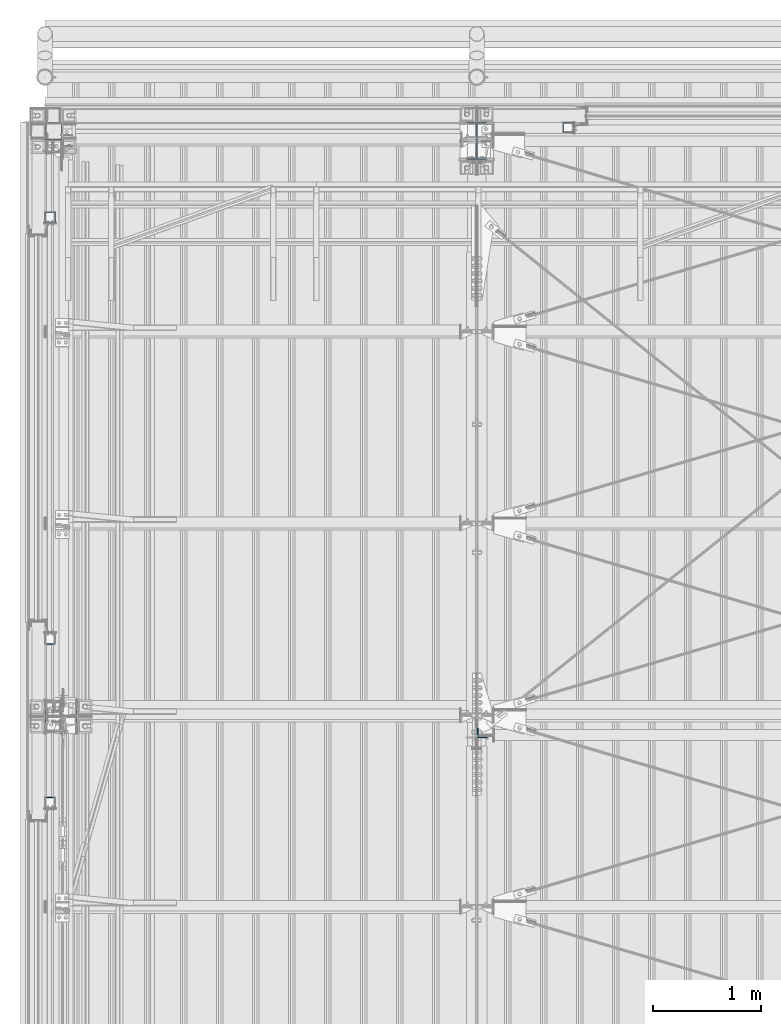
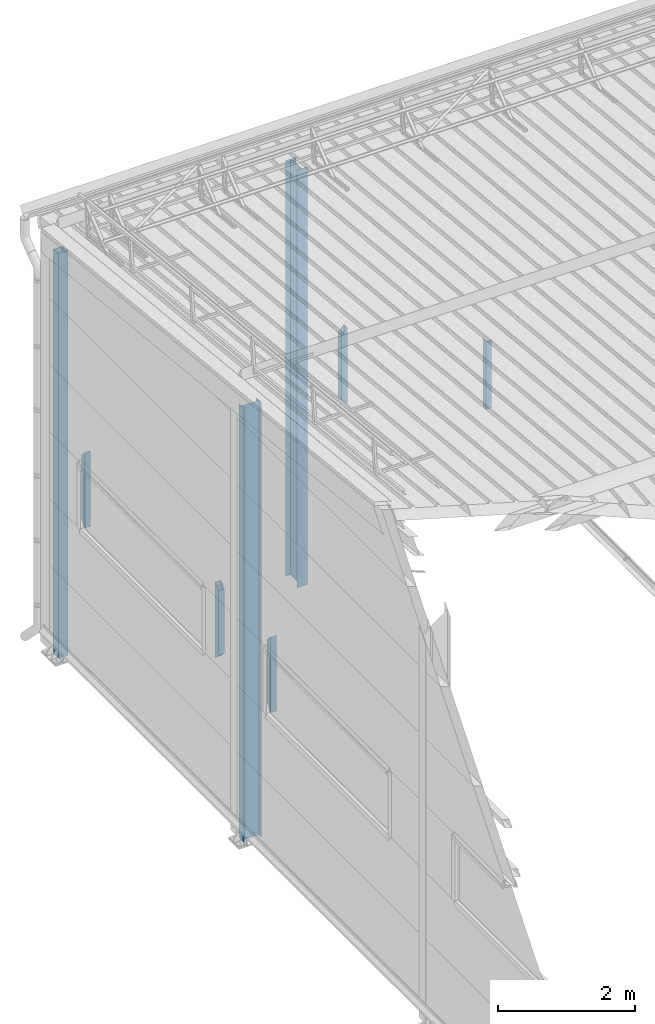
# One storey, part 230 of 709: 8 columns, 8 elements without a shape of their own.
"""IFC4 building model written with IfcOpenShell, lengths in millimetres."""

import ifcopenshell
import ifcopenshell.guid

model = None  # the IFC model being written
_history = None  # IfcOwnerHistory: only IFC2X3 demands one
_inside = {}  # id of a spatial element -> (the spatial element, [elements in it])
_under = {}  # id of a project, library or spatial element -> (it, [spatial elements below it])
_declared = {}  # id of a project -> (the project, [libraries it declares])
_typed = {}  # id of a type object -> (the type object, [elements of that type])
_made_of = {}  # id of a material, layer set ... -> (it, [elements and type objects made of it])


def new_model(schema):
    """Start an empty IFC model of exactly this schema.

    Asked for "IFC4X3", IfcOpenShell would pick the latest addendum, in which some entities
    have other attributes; the version numbers below select the first issue.
    IFC2X3 requires an IfcOwnerHistory on every rooted entity: one is made here for all.
    """
    global model, _history
    if schema == "IFC4X3":
        model = ifcopenshell.file(schema_version=(4, 3, 0, 0))
    else:
        model = ifcopenshell.file(schema=schema)
    _inside.clear()
    _under.clear()
    _declared.clear()
    _typed.clear()
    _made_of.clear()
    _history = None
    if model.schema == "IFC2X3":
        org = make("IfcOrganization", Name="unknown")
        user = make(
            "IfcPersonAndOrganization",
            ThePerson=make("IfcPerson", FamilyName="unknown"),
            TheOrganization=org,
        )
        app = make(
            "IfcApplication",
            ApplicationDeveloper=org,
            Version="unknown",
            ApplicationFullName="unknown",
            ApplicationIdentifier="unknown",
        )
        _history = make(
            "IfcOwnerHistory",
            OwningUser=user,
            OwningApplication=app,
            ChangeAction="ADDED",
            CreationDate=0,
        )
    return model


def make(cls, **values):
    """One entity of the class cls with the attributes given. An attribute that is None is left unset."""
    return model.create_entity(
        cls, **{name: value for name, value in values.items() if value is not None}
    )


def rooted(cls, **values):
    """An entity with a GlobalId (a new one), such as an element, a storey or a relation."""
    return make(cls, GlobalId=ifcopenshell.guid.new(), OwnerHistory=_history, **values)


def si_unit(unit_type, name, prefix=None):
    """IfcSIUnit, for example si_unit("LENGTHUNIT", "METRE", prefix="MILLI")."""
    return make("IfcSIUnit", UnitType=unit_type, Prefix=prefix, Name=name)


def assignment(units):
    """IfcUnitAssignment: the units of a project."""
    return None if units is None else make("IfcUnitAssignment", Units=units)


def point(xyz):
    """IfcCartesianPoint."""
    return None if xyz is None else make("IfcCartesianPoint", Coordinates=xyz)


def direction(xyz):
    """IfcDirection."""
    return None if xyz is None else make("IfcDirection", DirectionRatios=xyz)


def frame(location, z_axis=None, x_axis=None):
    """IfcAxis2Placement3D, a coordinate frame: its origin and axes. An axis left out is left unset."""
    return make(
        "IfcAxis2Placement3D",
        Location=point(location),
        Axis=direction(z_axis),
        RefDirection=direction(x_axis),
    )


def origin_with_axes():
    """The frame at (0, 0, 0) with the z axis (0, 0, 1) and the x axis (1, 0, 0) written out."""
    return frame((0.0, 0.0, 0.0), z_axis=(0.0, 0.0, 1.0), x_axis=(1.0, 0.0, 0.0))


def place(relative_to, where):
    """IfcLocalPlacement: puts the frame where relative to a parent placement (None: the world)."""
    return make(
        "IfcLocalPlacement", PlacementRelTo=relative_to, RelativePlacement=where
    )


def context(
    kind, dimensions, precision=None, world=None, true_north=None, identifier=None
):
    """IfcGeometricRepresentationContext, for example the 3D "Model" context."""
    return make(
        "IfcGeometricRepresentationContext",
        ContextIdentifier=identifier,
        ContextType=kind,
        CoordinateSpaceDimension=dimensions,
        Precision=precision,
        WorldCoordinateSystem=world,
        TrueNorth=true_north,
    )


def subcontext(parent, identifier, kind, view, scale=None):
    """IfcGeometricRepresentationSubContext, for example "Body" below "Model"."""
    return make(
        "IfcGeometricRepresentationSubContext",
        ContextIdentifier=identifier,
        ContextType=kind,
        ParentContext=parent,
        TargetScale=scale,
        TargetView=view,
    )


def project(units=None, contexts=None):
    """IfcProject with its units and contexts."""
    return rooted(
        "IfcProject",
        Name="project",
        RepresentationContexts=contexts,
        UnitsInContext=assignment(units),
    )


def spatial(cls, under=None, at=None, **own):
    """A site, building, storey or space (cls), placed at a placement, below another one or the project."""
    s = rooted(cls, ObjectPlacement=at, **own)
    if under is not None:
        _under.setdefault(under.id(), (under, []))[1].append(s)
    return s


def point_list(points):
    """IfcCartesianPointList2D or 3D."""
    cls = (
        "IfcCartesianPointList2D" if len(points[0]) == 2 else "IfcCartesianPointList3D"
    )
    return make(cls, CoordList=points)


def polygons(points, faces, closed=None, point_numbers=None):
    """IfcPolygonalFaceSet: a face is its outer loop, then its inner loops; points numbered from 1."""
    made = []
    for loops in faces:
        if len(loops) == 1:
            made.append(make("IfcIndexedPolygonalFace", CoordIndex=loops[0]))
        else:
            made.append(
                make(
                    "IfcIndexedPolygonalFaceWithVoids",
                    CoordIndex=loops[0],
                    InnerCoordIndices=loops[1:],
                )
            )
    return make(
        "IfcPolygonalFaceSet",
        Coordinates=point_list(points),
        Closed=closed,
        Faces=made,
        PnIndex=point_numbers,
    )


def shape(context_of_items, identifier, shape_type, items):
    """IfcShapeRepresentation: the items that make up one representation, for example the "Body"."""
    return make(
        "IfcShapeRepresentation",
        ContextOfItems=context_of_items,
        RepresentationIdentifier=identifier,
        RepresentationType=shape_type,
        Items=items,
    )


def material(Name=None, Category=None):
    """IfcMaterial."""
    return make("IfcMaterial", Name=Name, Category=Category)


def made_of(thing, what):
    """Note that an element or type object is made of a material, layer set ...; save() writes the relation."""
    if what is not None:
        _made_of.setdefault(what.id(), (what, []))[1].append(thing)
    return thing


def element(
    cls,
    number,
    at=None,
    inside=None,
    cuts=None,
    type_object=None,
    material=None,
    context=None,
    identifier="Body",
    shape_type=None,
    held_by="IfcProductDefinitionShape",
    body=None,
    shapes=None,
    **own,
):
    """One element of the class cls, such as IfcWall. Its Tag is "e" and its number.

    at: its placement. inside: the storey or other place that contains it. cuts: it is an
    opening in that element (IfcRelVoidsElement). A single representation is given by context,
    identifier, shape_type and body (its items); several are given by shapes. held_by: the class
    of the entity that holds the representations. save() writes the other relations.
    """
    e = rooted(cls, Tag="e%d" % number, ObjectPlacement=at, **own)
    if body is not None:
        shapes = [shape(context, identifier, shape_type, body)]
    if shapes is not None:
        e.Representation = make(held_by, Representations=shapes)
    if inside is not None:
        _inside.setdefault(inside.id(), (inside, []))[1].append(e)
    if cuts is not None:
        rooted(
            "IfcRelVoidsElement", RelatingBuildingElement=cuts, RelatedOpeningElement=e
        )
    if type_object is not None:
        _typed.setdefault(type_object.id(), (type_object, []))[1].append(e)
    return made_of(e, material)


def aggregate(whole, parts):
    """IfcRelAggregates: a whole, such as a stair, and the parts it consists of."""
    return rooted("IfcRelAggregates", RelatingObject=whole, RelatedObjects=parts)


def save(model, path):
    """Write the relations noted so far, then the file.

    IfcRelAggregates (storeys below a building ...), IfcRelContainedInSpatialStructure (elements
    in a storey), IfcRelDefinesByType, IfcRelAssociatesMaterial and IfcRelDeclares: one each for
    every whole, place, type object, material and project.
    """
    for whole, parts in _under.values():
        aggregate(whole, parts)
    for where, things in _inside.values():
        rooted(
            "IfcRelContainedInSpatialStructure",
            RelatedElements=things,
            RelatingStructure=where,
        )
    for kind, things in _typed.values():
        rooted("IfcRelDefinesByType", RelatedObjects=things, RelatingType=kind)
    for what, things in _made_of.values():
        rooted("IfcRelAssociatesMaterial", RelatedObjects=things, RelatingMaterial=what)
    for by, libraries in _declared.values():
        rooted("IfcRelDeclares", RelatingContext=by, RelatedDefinitions=libraries)
    model.write(path)


model = new_model("IFC4")

# Units and contexts
model_context = context("Model", 3, precision=0.2, world=origin_with_axes(), true_north=direction((0.0, 1.0)))
body_context = subcontext(model_context, "Body", "Model", "MODEL_VIEW")
ifc_project = project(units=[si_unit("LENGTHUNIT", "METRE", prefix="MILLI"), si_unit("AREAUNIT", "SQUARE_METRE"), si_unit("VOLUMEUNIT", "CUBIC_METRE"), si_unit("MASSUNIT", "GRAM", prefix="KILO"), si_unit("TIMEUNIT", "SECOND"), si_unit("PLANEANGLEUNIT", "RADIAN"), si_unit("SOLIDANGLEUNIT", "STERADIAN"), si_unit("THERMODYNAMICTEMPERATUREUNIT", "DEGREE_CELSIUS"), si_unit("LUMINOUSINTENSITYUNIT", "LUMEN")], contexts=[model_context])

# Site, building, storey
site_placement = place(None, origin_with_axes())
site = spatial("IfcSite", under=ifc_project, at=site_placement, CompositionType="ELEMENT")
building_placement = place(site_placement, origin_with_axes())
building = spatial("IfcBuilding", under=site, at=building_placement, Name="Undefined", CompositionType="ELEMENT")
storey_placement = place(building_placement, origin_with_axes())
storey = spatial("IfcBuildingStorey", under=building, at=storey_placement, Name="Undefined", CompositionType="ELEMENT", Elevation=0.0)

# Assembly, column
assembly_1_placement = place(storey_placement, frame((4000.0, 21827.0, -200.0), z_axis=(-1.0, 0.0, 0.0), x_axis=(0.0, 0.0, 1.0)))
assembly_1 = element("IfcElementAssembly", 1, at=assembly_1_placement, inside=storey)
ifc_material_1 = material(Name="C355-5", Category="STEEL")
column_1_placement = place(assembly_1_placement, origin_with_axes())
column_1 = element("IfcColumn", 2, at=column_1_placement, material=ifc_material_1, ObjectType="413", context=body_context, shape_type="Tessellation", body=[
    polygons([(25.0, -173.0, -87.0), (25.0, -164.0, -87.0), (7454.62297, -164.0, -87.0), (7455.52297, -173.0, -87.0), (25.0, -164.0, -3.0), (7454.62297, -164.0, -3.0), (25.0, 164.0, -3.0), (7421.82297, 164.0, -3.0), (25.0, 164.0, -87.0), (7421.82297, 164.0, -87.0), (25.0, 173.0, -87.0), (7420.92297, 173.0, -87.0), (25.0, 173.0, 87.0), (7420.92297, 173.0, 87.0), (25.0, 164.0, 87.0), (7421.82297, 164.0, 87.0), (25.0, 164.0, 3.0), (7421.82297, 164.0, 3.0), (25.0, -164.0, 3.0), (7454.62297, -164.0, 3.0), (25.0, -164.0, 87.0), (7454.62297, -164.0, 87.0), (25.0, -173.0, 87.0), (7455.52297, -173.0, 87.0)], [[[1, 2, 3, 4]], [[2, 5, 6, 3]], [[5, 7, 8, 6]], [[7, 9, 10, 8]], [[9, 11, 12, 10]], [[11, 13, 14, 12]], [[13, 15, 16, 14]], [[15, 17, 18, 16]], [[17, 19, 20, 18]], [[19, 21, 22, 20]], [[21, 23, 24, 22]], [[23, 1, 4, 24]], [[6, 8, 10, 12, 14, 16, 18, 20, 22, 24, 4, 3]], [[23, 21, 19, 17, 15, 13, 11, 9, 7, 5, 2, 1]]], closed=True),
])
aggregate(assembly_1, [column_1])

assembly_2_placement = place(storey_placement, frame((80.0, 21920.0, -200.0), z_axis=(0.0, -1.0, 0.0), x_axis=(0.0, 0.0, 1.0)))
assembly_2 = element("IfcElementAssembly", 3, at=assembly_2_placement, inside=storey)
ifc_material_2 = material(Name="C255-4", Category="STEEL")
column_2_placement = place(assembly_2_placement, origin_with_axes())
column_2 = element("IfcColumn", 4, at=column_2_placement, material=ifc_material_2, ObjectType="412", context=body_context, shape_type="Tessellation", body=[
    polygons([(25.0, -74.0, -74.0), (25.0, -74.0, 74.0), (7227.28556, -74.0, 74.0), (7212.48556, -74.0, -74.0), (25.0, 74.0, 74.0), (7227.28556, 74.0, 74.0), (25.0, 74.0, -74.0), (7212.48556, 74.0, -74.0), (25.0, -80.0, -80.0), (25.0, 80.0, -80.0), (7211.88556, 80.0, -80.0), (7211.88556, -80.0, -80.0), (25.0, 80.0, 80.0), (7227.88556, 80.0, 80.0), (25.0, -80.0, 80.0), (7227.88556, -80.0, 80.0)], [[[1, 2, 3, 4]], [[2, 5, 6, 3]], [[5, 7, 8, 6]], [[7, 1, 4, 8]], [[9, 10, 11, 12]], [[10, 13, 14, 11]], [[13, 15, 16, 14]], [[15, 9, 12, 16]], [[14, 16, 12, 11], [6, 8, 4, 3]], [[15, 13, 10, 9], [7, 5, 2, 1]]], closed=True),
])
aggregate(assembly_2, [column_2])

assembly_3_placement = place(storey_placement, frame((4051.0, 16347.7, 6024.30002), z_axis=(0.0, 1.0, 0.0), x_axis=(0.0, 0.0, 1.0)))
assembly_3 = element("IfcElementAssembly", 5, at=assembly_3_placement, inside=storey)
ifc_material_3 = material(Name="C345-5", Category="STEEL")
column_3_placement = place(assembly_3_placement, origin_with_axes())
column_3 = element("IfcColumn", 6, at=column_3_placement, material=ifc_material_3, ObjectType="436", context=body_context, shape_type="Tessellation", body=[
    polygons([(185.7, -45.0, -45.0), (185.7, 45.0, -45.0), (1399.4109, 45.0, -45.0), (1399.4109, -45.0, -45.0), (185.7, 45.0, -39.0), (1399.4109, 45.0, -39.0), (185.7, -39.0, -39.0), (1399.4109, -39.0, -39.0), (185.7, -39.0, 45.0), (1399.4109, -39.0, 45.0), (185.7, -45.0, 45.0), (1399.4109, -45.0, 45.0)], [[[1, 2, 3, 4]], [[2, 5, 6, 3]], [[5, 7, 8, 6]], [[7, 9, 10, 8]], [[9, 11, 12, 10]], [[11, 1, 4, 12]], [[6, 8, 10, 12, 4, 3]], [[11, 9, 7, 5, 2, 1]]], closed=True),
])
aggregate(assembly_3, [column_3])

assembly_4_placement = place(storey_placement, frame((50.0, 21120.0, 2600.0), z_axis=(0.0, -1.0, 0.0), x_axis=(0.0, 0.0, 1.0)))
assembly_4 = element("IfcElementAssembly", 7, at=assembly_4_placement, inside=storey)
ifc_material_4 = material(Name="C355", Category="STEEL")
column_4_placement = place(assembly_4_placement, origin_with_axes())
column_4 = element("IfcColumn", 8, at=column_4_placement, material=ifc_material_4, ObjectType="493", context=body_context, shape_type="Tessellation", body=[
    polygons([(10.0, -50.0, 50.0), (110.0, -50.0, -50.0), (1260.0, -50.0, -50.0), (1360.0, -50.0, 50.0), (10.0, 50.0, 50.0), (1360.0, 50.0, 50.0), (110.0, 50.0, -50.0), (1260.0, 50.0, -50.0), (13.0, -47.0, 47.0), (13.0, 47.0, 47.0), (1357.0, 47.0, 47.0), (1357.0, -47.0, 47.0), (107.0, -47.0, -47.0), (1263.0, -47.0, -47.0), (107.0, 47.0, -47.0), (1263.0, 47.0, -47.0)], [[[1, 2, 3, 4]], [[5, 1, 4, 6]], [[7, 5, 6, 8]], [[2, 7, 8, 3]], [[1, 5, 7, 2], [9, 13, 15, 10]], [[9, 10, 11, 12]], [[13, 9, 12, 14]], [[15, 13, 14, 16]], [[10, 15, 16, 11]], [[3, 8, 6, 4], [14, 12, 11, 16]]], closed=True),
])
aggregate(assembly_4, [column_4])

assembly_5_placement = place(storey_placement, frame((50.0, 17220.0, 2600.0), z_axis=(0.0, -1.0, 0.0), x_axis=(0.0, 0.0, 1.0)))
assembly_5 = element("IfcElementAssembly", 9, at=assembly_5_placement, inside=storey)
column_5_placement = place(assembly_5_placement, origin_with_axes())
column_5 = element("IfcColumn", 10, at=column_5_placement, material=ifc_material_4, ObjectType="493", context=body_context, shape_type="Tessellation", body=[
    polygons([(10.0, -50.0, -50.0), (10.0, 50.0, -50.0), (1360.0, 50.0, -50.0), (1360.0, -50.0, -50.0), (110.0, -50.0, 50.0), (1260.0, -50.0, 50.0), (110.0, 50.0, 50.0), (1260.0, 50.0, 50.0), (107.0, 47.0, 47.0), (13.0, 47.0, -47.0), (1357.0, 47.0, -47.0), (1263.0, 47.0, 47.0), (107.0, -47.0, 47.0), (1263.0, -47.0, 47.0), (13.0, -47.0, -47.0), (1357.0, -47.0, -47.0)], [[[1, 2, 3, 4]], [[5, 1, 4, 6]], [[7, 5, 6, 8]], [[2, 7, 8, 3]], [[1, 5, 7, 2], [15, 10, 9, 13]], [[9, 10, 11, 12]], [[13, 9, 12, 14]], [[15, 13, 14, 16]], [[10, 15, 16, 11]], [[6, 4, 3, 8], [14, 12, 11, 16]]], closed=True),
])
aggregate(assembly_5, [column_5])

assembly_6_placement = place(storey_placement, frame((50.0, 15700.0, 2600.0), z_axis=(0.0, -1.0, 0.0), x_axis=(0.0, 0.0, 1.0)))
assembly_6 = element("IfcElementAssembly", 11, at=assembly_6_placement, inside=storey)
column_6_placement = place(assembly_6_placement, origin_with_axes())
column_6 = element("IfcColumn", 12, at=column_6_placement, material=ifc_material_4, ObjectType="493", context=body_context, shape_type="Tessellation", body=[
    polygons([(10.0, -50.0, 50.0), (110.0, -50.0, -50.0), (1260.0, -50.0, -50.0), (1360.0, -50.0, 50.0), (10.0, 50.0, 50.0), (1360.0, 50.0, 50.0), (110.0, 50.0, -50.0), (1260.0, 50.0, -50.0), (13.0, -47.0, 47.0), (13.0, 47.0, 47.0), (1357.0, 47.0, 47.0), (1357.0, -47.0, 47.0), (107.0, -47.0, -47.0), (1263.0, -47.0, -47.0), (107.0, 47.0, -47.0), (1263.0, 47.0, -47.0)], [[[1, 2, 3, 4]], [[5, 1, 4, 6]], [[7, 5, 6, 8]], [[2, 7, 8, 3]], [[1, 5, 7, 2], [9, 13, 15, 10]], [[9, 10, 11, 12]], [[13, 9, 12, 14]], [[15, 13, 14, 16]], [[10, 15, 16, 11]], [[3, 8, 6, 4], [14, 12, 11, 16]]], closed=True),
])
aggregate(assembly_6, [column_6])

assembly_7_placement = place(storey_placement, frame((149.0, 16500.0, -200.0), z_axis=(0.0, -1.0, 0.0), x_axis=(0.0, 0.0, 1.0)))
assembly_7 = element("IfcElementAssembly", 13, at=assembly_7_placement, inside=storey)
column_7_placement = place(assembly_7_placement, origin_with_axes())
column_7 = element("IfcColumn", 14, at=column_7_placement, material=ifc_material_2, ObjectType="414", context=body_context, shape_type="Tessellation", body=[
    polygons([(25.0, -149.0, -74.5), (25.0, -141.0, -74.5), (7750.41561, -141.0, -74.5), (7750.41561, -149.0, -74.5), (25.0, -141.0, -2.75), (7757.59061, -141.0, -2.75), (25.0, 141.0, -2.75), (7757.59061, 141.0, -2.75), (25.0, 141.0, -74.5), (7750.41561, 141.0, -74.5), (25.0, 149.0, -74.5), (7750.41561, 149.0, -74.5), (25.0, 149.0, 74.5), (7765.31561, 149.0, 74.5), (25.0, 141.0, 74.5), (7765.31561, 141.0, 74.5), (25.0, 141.0, 2.75), (7758.14061, 141.0, 2.75), (25.0, -141.0, 2.75), (7758.14061, -141.0, 2.75), (25.0, -141.0, 74.5), (7765.31561, -141.0, 74.5), (25.0, -149.0, 74.5), (7765.31561, -149.0, 74.5)], [[[1, 2, 3, 4]], [[2, 5, 6, 3]], [[5, 7, 8, 6]], [[7, 9, 10, 8]], [[9, 11, 12, 10]], [[11, 13, 14, 12]], [[13, 15, 16, 14]], [[15, 17, 18, 16]], [[17, 19, 20, 18]], [[19, 21, 22, 20]], [[21, 23, 24, 22]], [[23, 1, 4, 24]], [[6, 8, 10, 12, 14, 16, 18, 20, 22, 24, 4, 3]], [[23, 21, 19, 17, 15, 13, 11, 9, 7, 5, 2, 1]]], closed=True),
])
aggregate(assembly_7, [column_7])

assembly_8_placement = place(storey_placement, frame((4850.0, 21950.0, 2600.0), z_axis=(-1.0, 0.0, 0.0), x_axis=(0.0, 0.0, 1.0)))
assembly_8 = element("IfcElementAssembly", 15, at=assembly_8_placement, inside=storey)
column_8_placement = place(assembly_8_placement, origin_with_axes())
column_8 = element("IfcColumn", 16, at=column_8_placement, material=ifc_material_4, ObjectType="493", context=body_context, shape_type="Tessellation", body=[
    polygons([(10.0, -50.0, -50.0), (10.0, 50.0, -50.0), (1360.0, 50.0, -50.0), (1360.0, -50.0, -50.0), (110.0, -50.0, 50.0), (1260.0, -50.0, 50.0), (110.0, 50.0, 50.0), (1260.0, 50.0, 50.0), (107.0, 47.0, 47.0), (13.0, 47.0, -47.0), (1357.0, 47.0, -47.0), (1263.0, 47.0, 47.0), (107.0, -47.0, 47.0), (1263.0, -47.0, 47.0), (13.0, -47.0, -47.0), (1357.0, -47.0, -47.0)], [[[1, 2, 3, 4]], [[5, 1, 4, 6]], [[7, 5, 6, 8]], [[2, 7, 8, 3]], [[1, 5, 7, 2], [15, 10, 9, 13]], [[9, 10, 11, 12]], [[13, 9, 12, 14]], [[15, 13, 14, 16]], [[10, 15, 16, 11]], [[6, 4, 3, 8], [14, 12, 11, 16]]], closed=True),
])
aggregate(assembly_8, [column_8])

save(model, "model.ifc")
